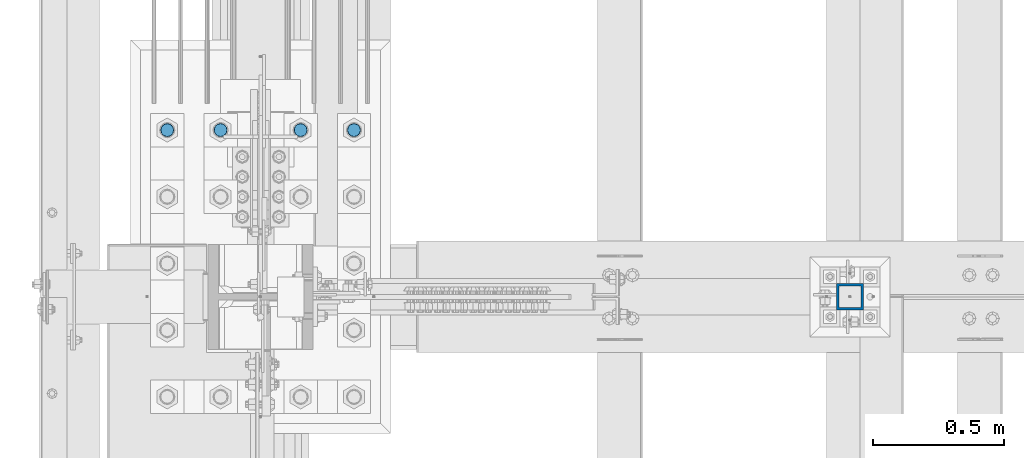
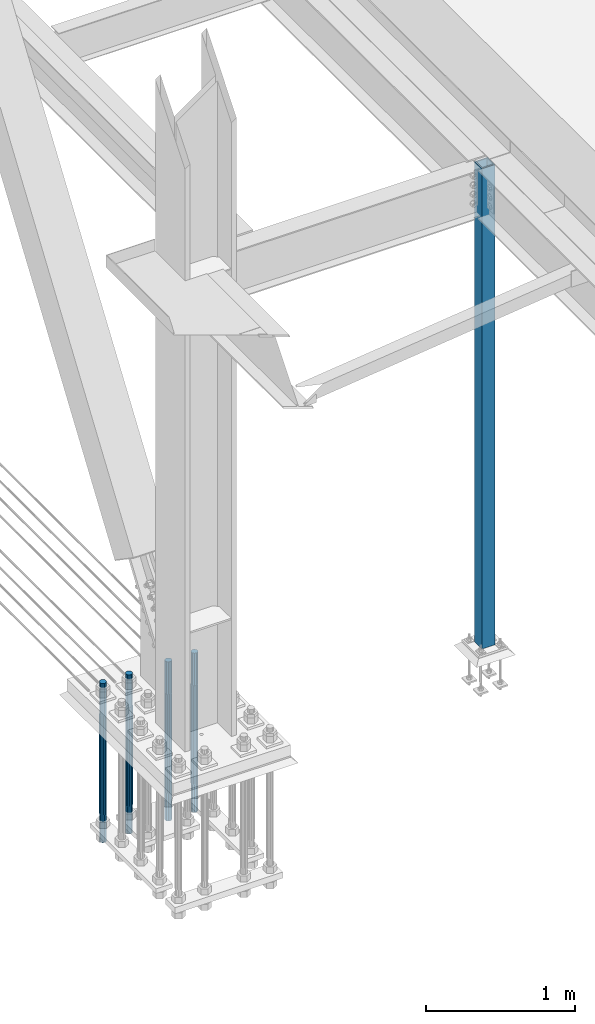
# One storey, part 1355 of 3843: 5 columns, 2 elements without a shape of their own.
"""IFC2X3 building model written with IfcOpenShell, lengths in millimetres."""

from ifc_helpers import new_model, si_unit, frame, origin_with_axes, place, context, subcontext, project, spatial, faceted_brep, material, type_object, element, aggregate, save


model = new_model("IFC2X3")

# Units and contexts
model_context = context("Model", 3, precision=1e-05, world=origin_with_axes())
body_context = subcontext(model_context, "Body", "Model", "MODEL_VIEW")
ifc_project = project(units=[si_unit("LENGTHUNIT", "METRE", prefix="MILLI"), si_unit("AREAUNIT", "SQUARE_METRE"), si_unit("VOLUMEUNIT", "CUBIC_METRE"), si_unit("MASSUNIT", "GRAM", prefix="KILO"), si_unit("TIMEUNIT", "SECOND"), si_unit("PLANEANGLEUNIT", "RADIAN"), si_unit("SOLIDANGLEUNIT", "STERADIAN"), si_unit("THERMODYNAMICTEMPERATUREUNIT", "DEGREE_CELSIUS"), si_unit("LUMINOUSINTENSITYUNIT", "LUMEN")], contexts=[model_context])

# Site, building, storey
site_placement = place(None, origin_with_axes())
site = spatial("IfcSite", under=ifc_project, at=site_placement, CompositionType="ELEMENT")
building_placement = place(site_placement, origin_with_axes())
building = spatial("IfcBuilding", under=site, at=building_placement, Name="Undefined", CompositionType="ELEMENT")
storey_placement = place(building_placement, origin_with_axes())
storey = spatial("IfcBuildingStorey", under=building, at=storey_placement, Name="Undefined", CompositionType="ELEMENT", Elevation=0.0)

# Assembly, column
assembly_1_placement = place(storey_placement, origin_with_axes())
assembly_1 = element("IfcElementAssembly", 1, at=assembly_1_placement, inside=storey, Name="COLUMN", AssemblyPlace="NOTDEFINED", PredefinedType="RIGID_FRAME")
ifc_material_1 = material()
column_type_1 = type_object("IfcColumnType", Name="HSS4X4X3/8", PredefinedType="NOTDEFINED")
column_1_placement = place(assembly_1_placement, frame((38820.725, 67271.9, 30022.8), z_axis=(-1.0, 0.0, 0.0), x_axis=(0.0, 0.0, 1.0)))
column_1 = element("IfcColumn", 2, at=column_1_placement, type_object=column_type_1, material=ifc_material_1, Name="COLUMN", ObjectType="HSS4X4X3/8", context=body_context, shape_type="Brep", body=[
    faceted_brep([(57.1500000000015, 41.2749999999942, -41.2750000000015), (57.1500000000015, -41.2749999999942, -41.2750000000015), (4000.5, -41.2749999999942, -41.2750000000015), (4000.5, 41.2749999999942, -41.2750000000015), (57.1500000000015, -41.2749999999942, 41.2750000000015), (4000.5, -41.2749999999942, 41.2750000000015), (57.1500000000015, 41.2749999999942, 41.2750000000015), (4000.5, 41.2749999999942, 41.2750000000015), (57.1500000000015, 50.8000000000029, -50.8000000000029), (57.1500000000015, 50.8000000000029, 50.8000000000029), (4000.5, 50.8000000000029, 50.8000000000029), (4000.5, 50.8000000000029, -50.8000000000029), (57.1500000000015, -50.8000000000029, 50.8000000000029), (4000.5, -50.8000000000029, 50.8000000000029), (57.1500000000015, -50.8000000000029, -50.8000000000029), (4000.5, -50.8000000000029, -50.8000000000029)], [[[0, 1, 2, 3]], [[1, 4, 5, 2]], [[4, 6, 7, 5]], [[6, 0, 3, 7]], [[8, 9, 10, 11]], [[9, 12, 13, 10]], [[12, 14, 15, 13]], [[14, 8, 11, 15]], [[13, 15, 11, 10], [5, 7, 3, 2]], [[14, 12, 9, 8], [6, 4, 1, 0]]]),
])
aggregate(assembly_1, [column_1])

# Assembly, columns
assembly_2_placement = place(storey_placement, origin_with_axes())
assembly_2 = element("IfcElementAssembly", 3, at=assembly_2_placement, inside=storey, Name="TEMPLATE", AssemblyPlace="NOTDEFINED", PredefinedType="RIGID_FRAME")
ifc_material_2 = material(Name="Undefined/F1554-GR.55")
column_type_2 = type_object("IfcColumnType", PredefinedType="NOTDEFINED")
column_2_placement = place(assembly_2_placement, frame((36931.6, 67906.9, 30022.8), z_axis=(-1.0, 0.0, 0.0), x_axis=(0.0, 0.0, -1.0)))
column_2 = element("IfcColumn", 4, at=column_2_placement, type_object=column_type_2, material=ifc_material_2, Name="ANCHOR_ROD", context=body_context, shape_type="Brep", body=[
    faceted_brep([(-266.700000000001, -21.2176223927236, 12.25), (-266.700000000001, -12.25, 21.2176223927163), (-266.700000000001, 0.0, 24.5), (-266.700000000001, 12.25, 21.2176223927163), (-266.700000000001, 21.2176223927236, 12.25), (-266.700000000001, 24.5, 0.0), (-266.700000000001, 21.2176223927236, -12.25), (-266.700000000001, 12.25, -21.2176223927163), (-266.700000000001, 0.0, -24.5), (-266.700000000001, -12.25, -21.2176223927163), (-266.700000000001, -21.2176223927236, -12.25), (-266.700000000001, -24.5, 0.0), (0.0, 24.5000000000146, 0.0), (0.0, 21.2176223927381, -12.25), (0.0, 12.2500000000146, -21.2176223927163), (0.0, 1.45519152283669e-11, -24.5), (0.0, -12.2499999999854, -21.2176223927163), (0.0, -21.217622392709, -12.25), (0.0, -24.4999999999854, 0.0), (0.0, -21.217622392709, 12.25), (0.0, -12.2499999999854, 21.2176223927163), (0.0, 1.45519152283669e-11, 24.5), (0.0, 12.2500000000146, 21.2176223927163), (0.0, 21.2176223927381, 12.25), (0.0, -23.4665401257807, 9.72015918207035), (0.0, -17.9605122421344, 17.9605122421417), (0.0, -9.72015918207762, 23.466540125788), (0.0, 0.0, 25.4000000000015), (0.0, 9.72015918207762, 23.466540125788), (0.0, 17.9605122421344, 17.9605122421417), (0.0, 23.4665401257807, 9.72015918207035), (0.0, 25.3999996185303, 0.0), (0.0, 23.4665401257807, -9.72015918207035), (0.0, 17.9605122421344, -17.9605122421417), (0.0, 9.72015918207762, -23.466540125788), (0.0, 0.0, -25.4000000000015), (0.0, -9.72015918207762, -23.466540125788), (0.0, -17.9605122421344, -17.9605122421417), (0.0, -23.4665401257807, -9.72015918207035), (0.0, -25.3999996185303, 0.0), (812.799999999999, -25.4000000000015, 0.0), (812.799999999999, -23.466540125788, 9.72015918207398), (812.799999999999, -17.9605122421417, 17.9605122421381), (812.799999999999, -9.72015918207035, 23.466540125788), (812.799999999999, 0.0, 25.4000000000015), (812.799999999999, 9.72015918207035, 23.466540125788), (812.799999999999, 17.9605122421417, 17.9605122421381), (812.799999999999, 23.466540125788, 9.72015918207398), (812.799999999999, 25.4000000000015, 0.0), (812.799999999999, 23.466540125788, -9.72015918207398), (812.799999999999, 17.9605122421417, -17.9605122421381), (812.799999999999, 9.72015918207035, -23.466540125788), (812.799999999999, 0.0, -25.4000000000015), (812.799999999999, -9.72015918207035, -23.466540125788), (812.799999999999, -17.9605122421417, -17.9605122421381), (812.799999999999, -23.466540125788, -9.72015918207398), (812.799999999999, -12.25, 21.2176223927199), (812.799999999999, 0.0, 24.5), (812.799999999999, 12.25, 21.2176223927199), (812.799999999999, 21.2176223927163, 12.25), (812.799999999999, 24.5, 0.0), (812.799999999999, 21.2176223927163, -12.25), (812.799999999999, 12.25, -21.2176223927199), (812.799999999999, 0.0, -24.5), (812.799999999999, -12.25, -21.2176223927199), (812.799999999999, -21.2176223927163, -12.25), (812.799999999999, -24.5, 0.0), (812.799999999999, -21.2176223927163, 12.25), (1041.4, -12.25, -21.2176223927199), (1041.4, 0.0, -24.5), (1041.4, 12.25, -21.2176223927199), (1041.4, 21.2176223927163, -12.25), (1041.4, 24.5, 0.0), (1041.4, 21.2176223927163, 12.25), (1041.4, 12.25, 21.2176223927199), (1041.4, 0.0, 24.5), (1041.4, -12.25, 21.2176223927199), (1041.4, -21.2176223927163, 12.25), (1041.4, -24.5, 0.0), (1041.4, -21.2176223927163, -12.25)], [[[0, 1, 2, 3, 4, 5, 6, 7, 8, 9, 10, 11]], [[6, 5, 12, 13]], [[7, 6, 13, 14]], [[8, 7, 14, 15]], [[9, 8, 15, 16]], [[10, 9, 16, 17]], [[11, 10, 17, 18]], [[0, 11, 18, 19]], [[1, 0, 19, 20]], [[2, 1, 20, 21]], [[3, 2, 21, 22]], [[4, 3, 22, 23]], [[5, 4, 23, 12]], [[24, 25, 26, 27, 28, 29, 30, 31, 32, 33, 34, 35, 36, 37, 38, 39], [22, 21, 20, 19, 18, 17, 16, 15, 14, 13, 12, 23]], [[24, 39, 40, 41]], [[25, 24, 41, 42]], [[26, 25, 42, 43]], [[27, 26, 43, 44]], [[28, 27, 44, 45]], [[29, 28, 45, 46]], [[30, 29, 46, 47]], [[31, 30, 47, 48]], [[32, 31, 48, 49]], [[33, 32, 49, 50]], [[34, 33, 50, 51]], [[35, 34, 51, 52]], [[36, 35, 52, 53]], [[37, 36, 53, 54]], [[38, 37, 54, 55]], [[39, 38, 55, 40]], [[54, 53, 52, 51, 50, 49, 48, 47, 46, 45, 44, 43, 42, 41, 40, 55], [56, 57, 58, 59, 60, 61, 62, 63, 64, 65, 66, 67]], [[68, 69, 70, 71, 72, 73, 74, 75, 76, 77, 78, 79]], [[76, 75, 57, 56]], [[77, 76, 56, 67]], [[78, 77, 67, 66]], [[79, 78, 66, 65]], [[68, 79, 65, 64]], [[69, 68, 64, 63]], [[70, 69, 63, 62]], [[71, 70, 62, 61]], [[72, 71, 61, 60]], [[73, 72, 60, 59]], [[74, 73, 59, 58]], [[75, 74, 58, 57]]]),
])
column_3_placement = place(assembly_2_placement, frame((36728.4, 67906.9, 30022.8), z_axis=(-1.0, 0.0, 0.0), x_axis=(0.0, 0.0, -1.0)))
column_3 = element("IfcColumn", 5, at=column_3_placement, type_object=column_type_2, material=ifc_material_2, Name="ANCHOR_ROD", context=body_context, shape_type="Brep", body=[
    faceted_brep([(-266.700000000001, -21.2176223927236, 12.25), (-266.700000000001, -12.25, 21.2176223927163), (-266.700000000001, 0.0, 24.5), (-266.700000000001, 12.25, 21.2176223927163), (-266.700000000001, 21.2176223927236, 12.25), (-266.700000000001, 24.5, 0.0), (-266.700000000001, 21.2176223927236, -12.25), (-266.700000000001, 12.25, -21.2176223927163), (-266.700000000001, 0.0, -24.5), (-266.700000000001, -12.25, -21.2176223927163), (-266.700000000001, -21.2176223927236, -12.25), (-266.700000000001, -24.5, 0.0), (0.0, 24.5000000000146, 0.0), (0.0, 21.2176223927381, -12.25), (0.0, 12.2500000000146, -21.2176223927163), (0.0, 1.45519152283669e-11, -24.5), (0.0, -12.2499999999854, -21.2176223927163), (0.0, -21.217622392709, -12.25), (0.0, -24.4999999999854, 0.0), (0.0, -21.217622392709, 12.25), (0.0, -12.2499999999854, 21.2176223927163), (0.0, 1.45519152283669e-11, 24.5), (0.0, 12.2500000000146, 21.2176223927163), (0.0, 21.2176223927381, 12.25), (0.0, -23.4665401257807, 9.72015918207035), (0.0, -17.9605122421344, 17.9605122421417), (0.0, -9.72015918207762, 23.466540125788), (0.0, 0.0, 25.4000000000015), (0.0, 9.72015918207762, 23.466540125788), (0.0, 17.9605122421344, 17.9605122421417), (0.0, 23.4665401257807, 9.72015918207035), (0.0, 25.3999996185303, 0.0), (0.0, 23.4665401257807, -9.72015918207035), (0.0, 17.9605122421344, -17.9605122421417), (0.0, 9.72015918207762, -23.466540125788), (0.0, 0.0, -25.4000000000015), (0.0, -9.72015918207762, -23.466540125788), (0.0, -17.9605122421344, -17.9605122421417), (0.0, -23.4665401257807, -9.72015918207035), (0.0, -25.3999996185303, 0.0), (812.799999999999, -25.4000000000015, 0.0), (812.799999999999, -23.466540125788, 9.72015918207398), (812.799999999999, -17.9605122421417, 17.9605122421381), (812.799999999999, -9.72015918207035, 23.466540125788), (812.799999999999, 0.0, 25.4000000000015), (812.799999999999, 9.72015918207035, 23.466540125788), (812.799999999999, 17.9605122421417, 17.9605122421381), (812.799999999999, 23.466540125788, 9.72015918207398), (812.799999999999, 25.4000000000015, 0.0), (812.799999999999, 23.466540125788, -9.72015918207398), (812.799999999999, 17.9605122421417, -17.9605122421381), (812.799999999999, 9.72015918207035, -23.466540125788), (812.799999999999, 0.0, -25.4000000000015), (812.799999999999, -9.72015918207035, -23.466540125788), (812.799999999999, -17.9605122421417, -17.9605122421381), (812.799999999999, -23.466540125788, -9.72015918207398), (812.799999999999, -12.25, 21.2176223927199), (812.799999999999, 0.0, 24.5), (812.799999999999, 12.25, 21.2176223927199), (812.799999999999, 21.2176223927163, 12.25), (812.799999999999, 24.5, 0.0), (812.799999999999, 21.2176223927163, -12.25), (812.799999999999, 12.25, -21.2176223927199), (812.799999999999, 0.0, -24.5), (812.799999999999, -12.25, -21.2176223927199), (812.799999999999, -21.2176223927163, -12.25), (812.799999999999, -24.5, 0.0), (812.799999999999, -21.2176223927163, 12.25), (1041.4, -12.25, -21.2176223927199), (1041.4, 0.0, -24.5), (1041.4, 12.25, -21.2176223927199), (1041.4, 21.2176223927163, -12.25), (1041.4, 24.5, 0.0), (1041.4, 21.2176223927163, 12.25), (1041.4, 12.25, 21.2176223927199), (1041.4, 0.0, 24.5), (1041.4, -12.25, 21.2176223927199), (1041.4, -21.2176223927163, 12.25), (1041.4, -24.5, 0.0), (1041.4, -21.2176223927163, -12.25)], [[[0, 1, 2, 3, 4, 5, 6, 7, 8, 9, 10, 11]], [[6, 5, 12, 13]], [[7, 6, 13, 14]], [[8, 7, 14, 15]], [[9, 8, 15, 16]], [[10, 9, 16, 17]], [[11, 10, 17, 18]], [[0, 11, 18, 19]], [[1, 0, 19, 20]], [[2, 1, 20, 21]], [[3, 2, 21, 22]], [[4, 3, 22, 23]], [[5, 4, 23, 12]], [[24, 25, 26, 27, 28, 29, 30, 31, 32, 33, 34, 35, 36, 37, 38, 39], [22, 21, 20, 19, 18, 17, 16, 15, 14, 13, 12, 23]], [[24, 39, 40, 41]], [[25, 24, 41, 42]], [[26, 25, 42, 43]], [[27, 26, 43, 44]], [[28, 27, 44, 45]], [[29, 28, 45, 46]], [[30, 29, 46, 47]], [[31, 30, 47, 48]], [[32, 31, 48, 49]], [[33, 32, 49, 50]], [[34, 33, 50, 51]], [[35, 34, 51, 52]], [[36, 35, 52, 53]], [[37, 36, 53, 54]], [[38, 37, 54, 55]], [[39, 38, 55, 40]], [[54, 53, 52, 51, 50, 49, 48, 47, 46, 45, 44, 43, 42, 41, 40, 55], [56, 57, 58, 59, 60, 61, 62, 63, 64, 65, 66, 67]], [[68, 69, 70, 71, 72, 73, 74, 75, 76, 77, 78, 79]], [[76, 75, 57, 56]], [[77, 76, 56, 67]], [[78, 77, 67, 66]], [[79, 78, 66, 65]], [[68, 79, 65, 64]], [[69, 68, 64, 63]], [[70, 69, 63, 62]], [[71, 70, 62, 61]], [[72, 71, 61, 60]], [[73, 72, 60, 59]], [[74, 73, 59, 58]], [[75, 74, 58, 57]]]),
])
column_4_placement = place(assembly_2_placement, frame((36423.6, 67906.9, 30022.8), z_axis=(-1.0, 0.0, 0.0), x_axis=(0.0, 0.0, -1.0)))
column_4 = element("IfcColumn", 6, at=column_4_placement, type_object=column_type_2, material=ifc_material_2, Name="ANCHOR_ROD", context=body_context, shape_type="Brep", body=[
    faceted_brep([(-266.700000000001, -21.2176223927236, 12.25), (-266.700000000001, -12.25, 21.2176223927163), (-266.700000000001, 0.0, 24.5), (-266.700000000001, 12.25, 21.2176223927163), (-266.700000000001, 21.2176223927236, 12.25), (-266.700000000001, 24.5, 0.0), (-266.700000000001, 21.2176223927236, -12.25), (-266.700000000001, 12.25, -21.2176223927163), (-266.700000000001, 0.0, -24.5), (-266.700000000001, -12.25, -21.2176223927163), (-266.700000000001, -21.2176223927236, -12.25), (-266.700000000001, -24.5, 0.0), (0.0, 24.5000000000146, 0.0), (0.0, 21.2176223927381, -12.25), (0.0, 12.2500000000146, -21.2176223927163), (0.0, 1.45519152283669e-11, -24.5), (0.0, -12.2499999999854, -21.2176223927163), (0.0, -21.217622392709, -12.25), (0.0, -24.4999999999854, 0.0), (0.0, -21.217622392709, 12.25), (0.0, -12.2499999999854, 21.2176223927163), (0.0, 1.45519152283669e-11, 24.5), (0.0, 12.2500000000146, 21.2176223927163), (0.0, 21.2176223927381, 12.25), (0.0, -23.4665401257807, 9.72015918207035), (0.0, -17.9605122421344, 17.9605122421417), (0.0, -9.72015918207762, 23.466540125788), (0.0, 0.0, 25.4000000000015), (0.0, 9.72015918207762, 23.466540125788), (0.0, 17.9605122421344, 17.9605122421417), (0.0, 23.4665401257807, 9.72015918207035), (0.0, 25.3999996185303, 0.0), (0.0, 23.4665401257807, -9.72015918207035), (0.0, 17.9605122421344, -17.9605122421417), (0.0, 9.72015918207762, -23.466540125788), (0.0, 0.0, -25.4000000000015), (0.0, -9.72015918207762, -23.466540125788), (0.0, -17.9605122421344, -17.9605122421417), (0.0, -23.4665401257807, -9.72015918207035), (0.0, -25.3999996185303, 0.0), (812.799999999999, -25.4000000000015, 0.0), (812.799999999999, -23.466540125788, 9.72015918207398), (812.799999999999, -17.9605122421417, 17.9605122421381), (812.799999999999, -9.72015918207035, 23.466540125788), (812.799999999999, 0.0, 25.4000000000015), (812.799999999999, 9.72015918207035, 23.466540125788), (812.799999999999, 17.9605122421417, 17.9605122421381), (812.799999999999, 23.466540125788, 9.72015918207398), (812.799999999999, 25.4000000000015, 0.0), (812.799999999999, 23.466540125788, -9.72015918207398), (812.799999999999, 17.9605122421417, -17.9605122421381), (812.799999999999, 9.72015918207035, -23.466540125788), (812.799999999999, 0.0, -25.4000000000015), (812.799999999999, -9.72015918207035, -23.466540125788), (812.799999999999, -17.9605122421417, -17.9605122421381), (812.799999999999, -23.466540125788, -9.72015918207398), (812.799999999999, -12.25, 21.2176223927199), (812.799999999999, 0.0, 24.5), (812.799999999999, 12.25, 21.2176223927199), (812.799999999999, 21.2176223927163, 12.25), (812.799999999999, 24.5, 0.0), (812.799999999999, 21.2176223927163, -12.25), (812.799999999999, 12.25, -21.2176223927199), (812.799999999999, 0.0, -24.5), (812.799999999999, -12.25, -21.2176223927199), (812.799999999999, -21.2176223927163, -12.25), (812.799999999999, -24.5, 0.0), (812.799999999999, -21.2176223927163, 12.25), (1041.4, -12.25, -21.2176223927199), (1041.4, 0.0, -24.5), (1041.4, 12.25, -21.2176223927199), (1041.4, 21.2176223927163, -12.25), (1041.4, 24.5, 0.0), (1041.4, 21.2176223927163, 12.25), (1041.4, 12.25, 21.2176223927199), (1041.4, 0.0, 24.5), (1041.4, -12.25, 21.2176223927199), (1041.4, -21.2176223927163, 12.25), (1041.4, -24.5, 0.0), (1041.4, -21.2176223927163, -12.25)], [[[0, 1, 2, 3, 4, 5, 6, 7, 8, 9, 10, 11]], [[6, 5, 12, 13]], [[7, 6, 13, 14]], [[8, 7, 14, 15]], [[9, 8, 15, 16]], [[10, 9, 16, 17]], [[11, 10, 17, 18]], [[0, 11, 18, 19]], [[1, 0, 19, 20]], [[2, 1, 20, 21]], [[3, 2, 21, 22]], [[4, 3, 22, 23]], [[5, 4, 23, 12]], [[24, 25, 26, 27, 28, 29, 30, 31, 32, 33, 34, 35, 36, 37, 38, 39], [22, 21, 20, 19, 18, 17, 16, 15, 14, 13, 12, 23]], [[24, 39, 40, 41]], [[25, 24, 41, 42]], [[26, 25, 42, 43]], [[27, 26, 43, 44]], [[28, 27, 44, 45]], [[29, 28, 45, 46]], [[30, 29, 46, 47]], [[31, 30, 47, 48]], [[32, 31, 48, 49]], [[33, 32, 49, 50]], [[34, 33, 50, 51]], [[35, 34, 51, 52]], [[36, 35, 52, 53]], [[37, 36, 53, 54]], [[38, 37, 54, 55]], [[39, 38, 55, 40]], [[54, 53, 52, 51, 50, 49, 48, 47, 46, 45, 44, 43, 42, 41, 40, 55], [56, 57, 58, 59, 60, 61, 62, 63, 64, 65, 66, 67]], [[68, 69, 70, 71, 72, 73, 74, 75, 76, 77, 78, 79]], [[76, 75, 57, 56]], [[77, 76, 56, 67]], [[78, 77, 67, 66]], [[79, 78, 66, 65]], [[68, 79, 65, 64]], [[69, 68, 64, 63]], [[70, 69, 63, 62]], [[71, 70, 62, 61]], [[72, 71, 61, 60]], [[73, 72, 60, 59]], [[74, 73, 59, 58]], [[75, 74, 58, 57]]]),
])
column_5_placement = place(assembly_2_placement, frame((36220.4, 67906.9, 30022.8), z_axis=(-1.0, 0.0, 0.0), x_axis=(0.0, 0.0, -1.0)))
column_5 = element("IfcColumn", 7, at=column_5_placement, type_object=column_type_2, material=ifc_material_2, Name="ANCHOR_ROD", context=body_context, shape_type="Brep", body=[
    faceted_brep([(-266.700000000001, -21.2176223927236, 12.25), (-266.700000000001, -12.25, 21.2176223927163), (-266.700000000001, 0.0, 24.5), (-266.700000000001, 12.25, 21.2176223927163), (-266.700000000001, 21.2176223927236, 12.25), (-266.700000000001, 24.5, 0.0), (-266.700000000001, 21.2176223927236, -12.25), (-266.700000000001, 12.25, -21.2176223927163), (-266.700000000001, 0.0, -24.5), (-266.700000000001, -12.25, -21.2176223927163), (-266.700000000001, -21.2176223927236, -12.25), (-266.700000000001, -24.5, 0.0), (0.0, 24.5000000000146, 0.0), (0.0, 21.2176223927381, -12.25), (0.0, 12.2500000000146, -21.2176223927163), (0.0, 1.45519152283669e-11, -24.5), (0.0, -12.2499999999854, -21.2176223927163), (0.0, -21.217622392709, -12.25), (0.0, -24.4999999999854, 0.0), (0.0, -21.217622392709, 12.25), (0.0, -12.2499999999854, 21.2176223927163), (0.0, 1.45519152283669e-11, 24.5), (0.0, 12.2500000000146, 21.2176223927163), (0.0, 21.2176223927381, 12.25), (0.0, -23.4665401257807, 9.72015918207035), (0.0, -17.9605122421344, 17.9605122421417), (0.0, -9.72015918207762, 23.466540125788), (0.0, 0.0, 25.4000000000015), (0.0, 9.72015918207762, 23.466540125788), (0.0, 17.9605122421344, 17.9605122421417), (0.0, 23.4665401257807, 9.72015918207035), (0.0, 25.3999996185303, 0.0), (0.0, 23.4665401257807, -9.72015918207035), (0.0, 17.9605122421344, -17.9605122421417), (0.0, 9.72015918207762, -23.466540125788), (0.0, 0.0, -25.4000000000015), (0.0, -9.72015918207762, -23.466540125788), (0.0, -17.9605122421344, -17.9605122421417), (0.0, -23.4665401257807, -9.72015918207035), (0.0, -25.3999996185303, 0.0), (812.799999999999, -25.4000000000015, 0.0), (812.799999999999, -23.466540125788, 9.72015918207398), (812.799999999999, -17.9605122421417, 17.9605122421381), (812.799999999999, -9.72015918207035, 23.466540125788), (812.799999999999, 0.0, 25.4000000000015), (812.799999999999, 9.72015918207035, 23.466540125788), (812.799999999999, 17.9605122421417, 17.9605122421381), (812.799999999999, 23.466540125788, 9.72015918207398), (812.799999999999, 25.4000000000015, 0.0), (812.799999999999, 23.466540125788, -9.72015918207398), (812.799999999999, 17.9605122421417, -17.9605122421381), (812.799999999999, 9.72015918207035, -23.466540125788), (812.799999999999, 0.0, -25.4000000000015), (812.799999999999, -9.72015918207035, -23.466540125788), (812.799999999999, -17.9605122421417, -17.9605122421381), (812.799999999999, -23.466540125788, -9.72015918207398), (812.799999999999, -12.25, 21.2176223927199), (812.799999999999, 0.0, 24.5), (812.799999999999, 12.25, 21.2176223927199), (812.799999999999, 21.2176223927163, 12.25), (812.799999999999, 24.5, 0.0), (812.799999999999, 21.2176223927163, -12.25), (812.799999999999, 12.25, -21.2176223927199), (812.799999999999, 0.0, -24.5), (812.799999999999, -12.25, -21.2176223927199), (812.799999999999, -21.2176223927163, -12.25), (812.799999999999, -24.5, 0.0), (812.799999999999, -21.2176223927163, 12.25), (1041.4, -12.25, -21.2176223927199), (1041.4, 0.0, -24.5), (1041.4, 12.25, -21.2176223927199), (1041.4, 21.2176223927163, -12.25), (1041.4, 24.5, 0.0), (1041.4, 21.2176223927163, 12.25), (1041.4, 12.25, 21.2176223927199), (1041.4, 0.0, 24.5), (1041.4, -12.25, 21.2176223927199), (1041.4, -21.2176223927163, 12.25), (1041.4, -24.5, 0.0), (1041.4, -21.2176223927163, -12.25)], [[[0, 1, 2, 3, 4, 5, 6, 7, 8, 9, 10, 11]], [[6, 5, 12, 13]], [[7, 6, 13, 14]], [[8, 7, 14, 15]], [[9, 8, 15, 16]], [[10, 9, 16, 17]], [[11, 10, 17, 18]], [[0, 11, 18, 19]], [[1, 0, 19, 20]], [[2, 1, 20, 21]], [[3, 2, 21, 22]], [[4, 3, 22, 23]], [[5, 4, 23, 12]], [[24, 25, 26, 27, 28, 29, 30, 31, 32, 33, 34, 35, 36, 37, 38, 39], [22, 21, 20, 19, 18, 17, 16, 15, 14, 13, 12, 23]], [[24, 39, 40, 41]], [[25, 24, 41, 42]], [[26, 25, 42, 43]], [[27, 26, 43, 44]], [[28, 27, 44, 45]], [[29, 28, 45, 46]], [[30, 29, 46, 47]], [[31, 30, 47, 48]], [[32, 31, 48, 49]], [[33, 32, 49, 50]], [[34, 33, 50, 51]], [[35, 34, 51, 52]], [[36, 35, 52, 53]], [[37, 36, 53, 54]], [[38, 37, 54, 55]], [[39, 38, 55, 40]], [[54, 53, 52, 51, 50, 49, 48, 47, 46, 45, 44, 43, 42, 41, 40, 55], [56, 57, 58, 59, 60, 61, 62, 63, 64, 65, 66, 67]], [[68, 69, 70, 71, 72, 73, 74, 75, 76, 77, 78, 79]], [[76, 75, 57, 56]], [[77, 76, 56, 67]], [[78, 77, 67, 66]], [[79, 78, 66, 65]], [[68, 79, 65, 64]], [[69, 68, 64, 63]], [[70, 69, 63, 62]], [[71, 70, 62, 61]], [[72, 71, 61, 60]], [[73, 72, 60, 59]], [[74, 73, 59, 58]], [[75, 74, 58, 57]]]),
])
aggregate(assembly_2, [column_2, column_3, column_4, column_5])

save(model, "model.ifc")
